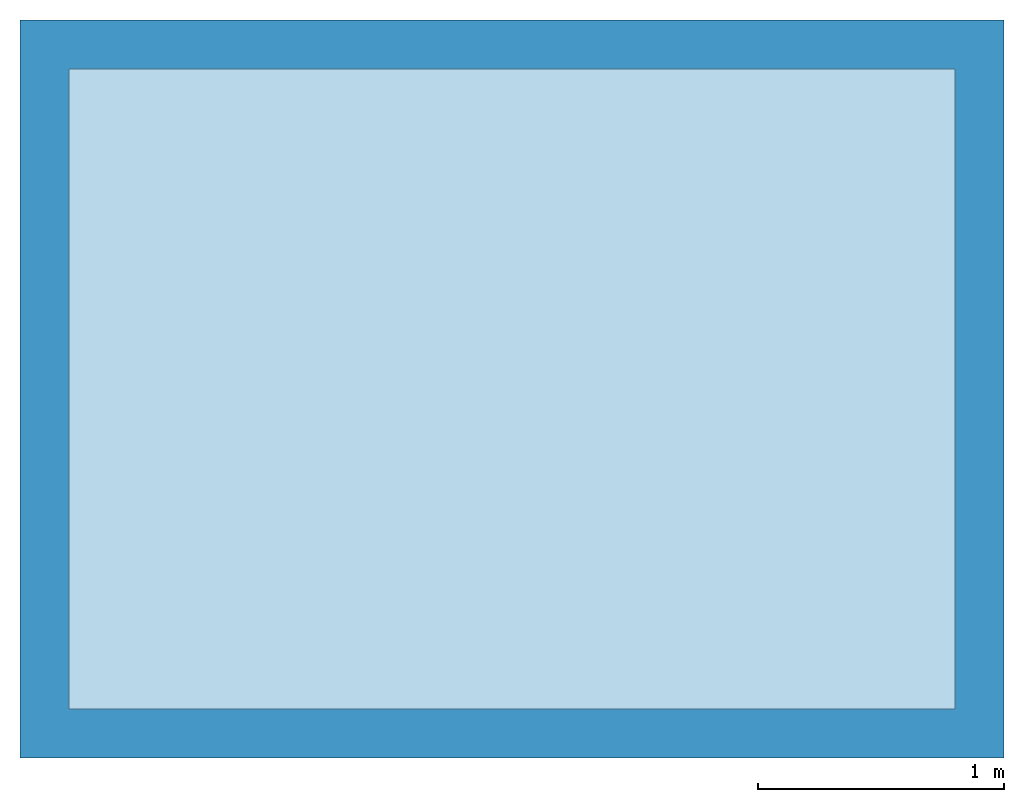
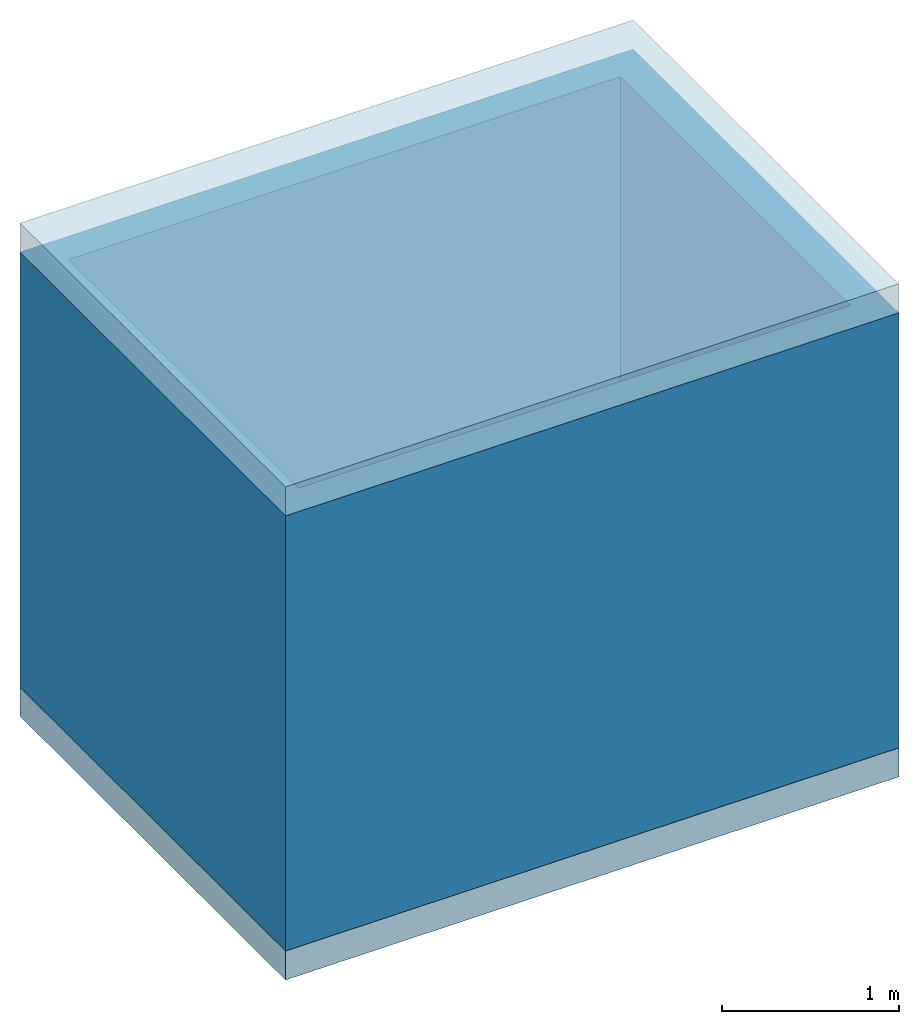
# One storey: 2 slabs, 1 wall.
"""IFC4 building model written with IfcOpenShell, lengths in metres."""

from ifc_helpers import new_model, si_unit, frame, origin_with_axes, place, context, subcontext, project, spatial, polygons, source, transform, mapped, element, save


model = new_model("IFC4")

# Units and contexts
model_context = context("Model", 3, precision=1e-05, world=origin_with_axes())
plan_context = context("Plan", 2, precision=1e-05, world=origin_with_axes())
body_context = subcontext(model_context, "Body", "Model", "MODEL_VIEW")
ifc_project = project(units=[si_unit("LENGTHUNIT", "METRE"), si_unit("AREAUNIT", "SQUARE_METRE"), si_unit("VOLUMEUNIT", "CUBIC_METRE")], contexts=[model_context, plan_context])

# Site, building, storey
site_placement = place(None, origin_with_axes())
site = spatial("IfcSite", under=ifc_project, at=site_placement)
building_placement = place(site_placement, origin_with_axes())
building = spatial("IfcBuilding", under=site, at=building_placement, Name="Building")
storey_placement = place(building_placement, origin_with_axes())
storey = spatial("IfcBuildingStorey", under=building, at=storey_placement, Name="Ground Floor")

# Slabs
shared_shape_1 = source(origin_with_axes(), body_context, "Body", "Tessellation", [
    polygons([(0.0, 0.0, -0.200000002980232), (0.0, 3.0, -0.200000002980232), (4.0, 3.0, -0.200000002980232), (4.0, 0.0, -0.200000002980232), (4.0, 3.0, 0.0), (4.0, 0.0, 0.0), (0.0, 0.0, 0.0), (0.0, 3.0, 0.0), (4.0, 3.0, 0.0), (4.0, 0.0, 0.0), (4.0, 3.0, 0.0), (4.0, 0.0, 0.0)], [[[1, 2, 3, 4]], [[7, 10, 9, 8]], [[1, 4, 10, 7]], [[2, 1, 7, 8]], [[3, 2, 8, 9]], [[4, 3, 9, 10]]]),
])
slab_1_placement = place(storey_placement, frame((0.0, 0.0, 3.20000004768372), z_axis=(0.0, 0.0, 1.0), x_axis=(1.0, 0.0, 0.0)))
element("IfcSlab", 1, at=slab_1_placement, inside=storey, Name="Slab.001", PredefinedType="FLOOR", context=body_context, shape_type="MappedRepresentation", body=[
    mapped(shared_shape_1, transform((0.0, 0.0, 0.0), x_axis=(1.0, 0.0, 0.0), y_axis=(0.0, 1.0, 0.0), z_axis=(0.0, 0.0, 1.0), scale=1.0)),
])
shared_shape_2 = source(origin_with_axes(), body_context, "Body", "Tessellation", [
    polygons([(0.0, 0.0, -0.200000002980232), (0.0, 3.0, -0.200000002980232), (4.0, 3.0, -0.200000002980232), (4.0, 0.0, -0.200000002980232), (4.0, 3.0, 0.0), (4.0, 0.0, 0.0), (0.0, 0.0, 0.0), (0.0, 3.0, 0.0), (4.0, 3.0, 0.0), (4.0, 0.0, 0.0), (4.0, 3.0, 0.0), (4.0, 0.0, 0.0)], [[[1, 2, 3, 4]], [[7, 10, 9, 8]], [[1, 4, 10, 7]], [[2, 1, 7, 8]], [[3, 2, 8, 9]], [[4, 3, 9, 10]]]),
])
slab_2_placement = place(storey_placement, origin_with_axes())
element("IfcSlab", 2, at=slab_2_placement, inside=storey, Name="Slab", PredefinedType="FLOOR", context=body_context, shape_type="MappedRepresentation", body=[
    mapped(shared_shape_2, transform((0.0, 0.0, 0.0), x_axis=(1.0, 0.0, 0.0), y_axis=(0.0, 1.0, 0.0), z_axis=(0.0, 0.0, 1.0), scale=1.0)),
])

# Wall
shared_shape_3 = source(origin_with_axes(), body_context, "Body", "Tessellation", [
    polygons([(0.0, 0.0, 0.0), (4.0, 0.0, 0.0), (4.0, 3.0, 0.0), (0.0, 3.0, 0.0), (0.0, 0.200000002980232, 0.0), (0.0, 0.0, 3.0), (4.0, 0.0, 3.0), (4.0, 3.0, 3.0), (0.0, 3.0, 3.0), (0.0, 0.200000002980232, 3.0), (0.0, 0.200000002980232, 0.0), (3.79999995231628, 0.200000002980232, 0.0), (3.79999995231628, 2.79999995231628, 0.0), (0.200000002980232, 2.79999995231628, 0.0), (0.200000002980232, 0.200000002980232, 0.0), (0.0, 0.200000002980232, 3.0), (3.79999995231628, 0.200000002980232, 3.0), (3.79999995231628, 2.79999995231628, 3.0), (0.200000002980232, 2.79999995231628, 3.0), (0.200000002980232, 0.200000002980232, 3.0)], [[[7, 6, 1, 2]], [[8, 7, 2, 3]], [[9, 8, 3, 4]], [[10, 9, 4, 5]], [[17, 12, 11, 16]], [[18, 13, 12, 17]], [[19, 14, 13, 18]], [[20, 15, 14, 19]], [[2, 1, 11, 12]], [[3, 2, 12, 13]], [[4, 3, 13, 14]], [[5, 4, 14, 15]], [[1, 6, 16, 11]], [[10, 5, 15, 20]], [[6, 7, 17, 16]], [[7, 8, 18, 17]], [[8, 9, 19, 18]], [[9, 10, 20, 19]]]),
])
wall_placement = place(storey_placement, origin_with_axes())
element("IfcWall", 3, at=wall_placement, inside=storey, Name="Wall", PredefinedType="STANDARD", context=body_context, shape_type="MappedRepresentation", body=[
    mapped(shared_shape_3, transform((0.0, 0.0, 0.0), x_axis=(1.0, 0.0, 0.0), y_axis=(0.0, 1.0, 0.0), z_axis=(0.0, 0.0, 1.0), scale=1.0)),
])

save(model, "model.ifc")
